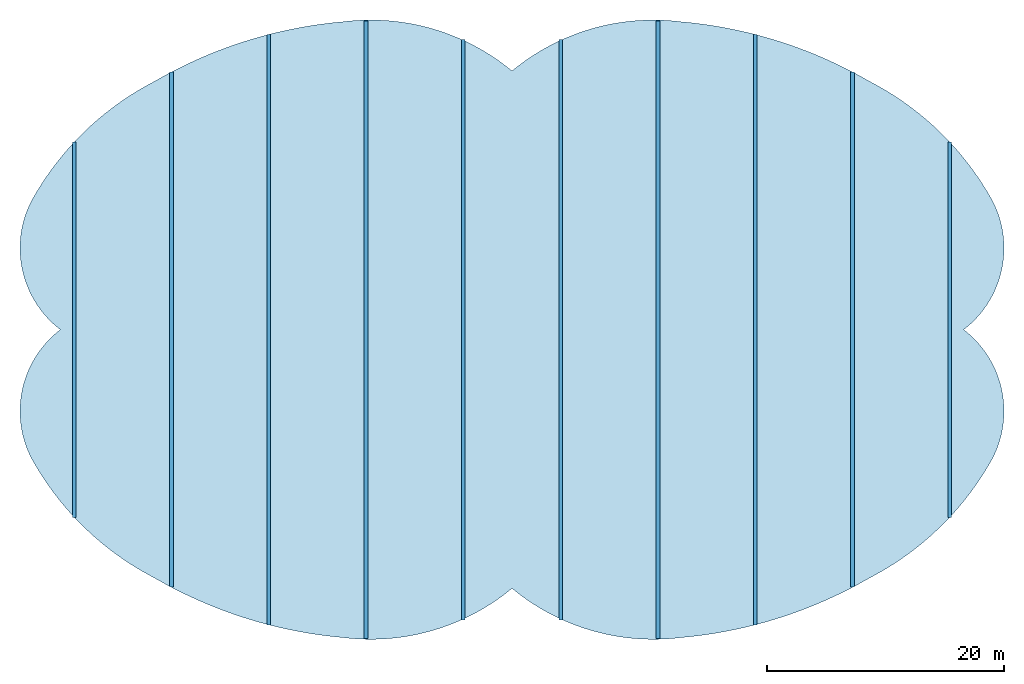
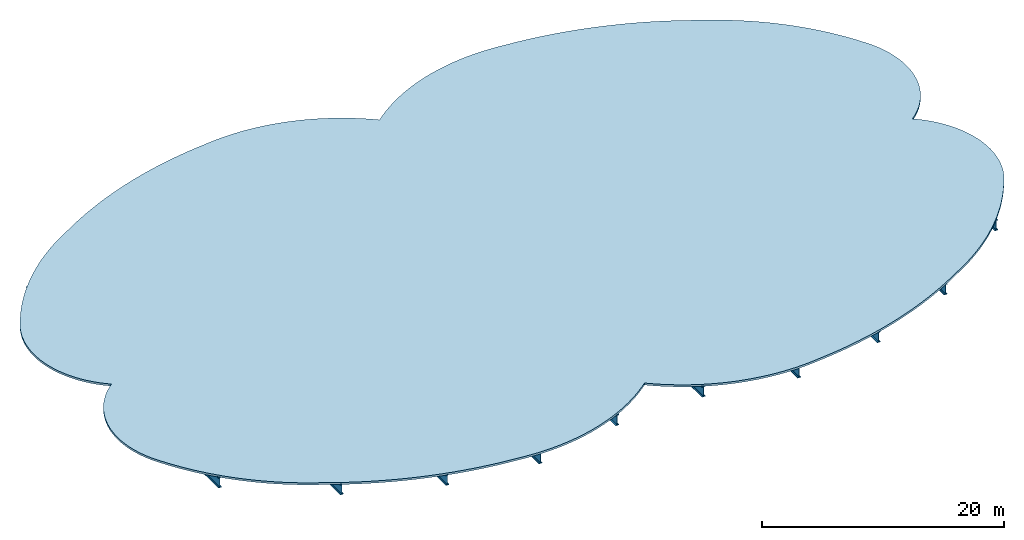
# One storey: 10 beams, 1 slab.
"""IFC2X3 building model written with IfcOpenShell, lengths in metres."""

from ifc_helpers import new_model, si_unit, point, direction, frame, frame_2d, origin_with_axes, origin_2d, place, context, project, spatial, circle_curve, parameter, trimmed, segment, composite_curve, i_section, outline, extrude, element, save


model = new_model("IFC2X3")

# Units and contexts
model_context = context("Model", 3, precision=1e-05, world=origin_with_axes(), true_north=direction((0.0, 1.0, 0.0)), identifier="Body")
ifc_project = project(units=[si_unit("LENGTHUNIT", "METRE"), si_unit("AREAUNIT", "SQUARE_METRE"), si_unit("VOLUMEUNIT", "CUBIC_METRE"), si_unit("PLANEANGLEUNIT", "RADIAN")], contexts=[model_context])

# Site, building, storey
site_placement = place(None, origin_with_axes())
site = spatial("IfcSite", under=ifc_project, at=site_placement, CompositionType="ELEMENT")
building_placement = place(None, origin_with_axes())
building = spatial("IfcBuilding", under=site, at=building_placement, Name="GH DEMO", CompositionType="ELEMENT")
storey_placement = place(None, origin_with_axes())
storey = spatial("IfcBuildingStorey", under=building, at=storey_placement, Name="FIRST FLOOR", CompositionType="ELEMENT", Elevation=3.0)

# Beams
beam_1_placement = place(None, origin_with_axes())
element("IfcBeam", 1, at=beam_1_placement, inside=storey, context=model_context, shape_type="SweptSolid", body=[
    extrude(i_section(OverallWidth=0.314, OverallDepth=1.056, WebThickness=0.036, FlangeThickness=0.064, FilletRadius=0.03, at=origin_2d()), frame((4.1125, -24.5321158359134, 2.5), z_axis=(0.0, 1.0, 0.0), x_axis=(-1.0, 0.0, 0.0)), (0.0, 0.0, 1.0), 49.0642316718267),
])
beam_2_placement = place(None, origin_with_axes())
element("IfcBeam", 2, at=beam_2_placement, inside=storey, context=model_context, shape_type="SweptSolid", body=[
    extrude(i_section(OverallWidth=0.314, OverallDepth=1.056, WebThickness=0.036, FlangeThickness=0.064, FilletRadius=0.03, at=origin_2d()), frame((12.3375, -26.1006955766967, 2.5), z_axis=(0.0, 1.0, 0.0), x_axis=(-1.0, 0.0, 0.0)), (0.0, 0.0, 1.0), 52.2013911533934),
])
beam_3_placement = place(None, origin_with_axes())
element("IfcBeam", 3, at=beam_3_placement, inside=storey, context=model_context, shape_type="SweptSolid", body=[
    extrude(i_section(OverallWidth=0.314, OverallDepth=1.056, WebThickness=0.036, FlangeThickness=0.064, FilletRadius=0.03, at=origin_2d()), frame((20.5625, -24.966524792191, 2.5), z_axis=(0.0, 1.0, 0.0), x_axis=(-1.0, 0.0, 0.0)), (0.0, 0.0, 1.0), 49.9330495843819),
])
beam_4_placement = place(None, origin_with_axes())
element("IfcBeam", 4, at=beam_4_placement, inside=storey, context=model_context, shape_type="SweptSolid", body=[
    extrude(i_section(OverallWidth=0.314, OverallDepth=1.056, WebThickness=0.036, FlangeThickness=0.064, FilletRadius=0.03, at=origin_2d()), frame((28.7875, -21.7760600789549, 2.5), z_axis=(0.0, 1.0, 0.0), x_axis=(-1.0, 0.0, 0.0)), (0.0, 0.0, 1.0), 43.5521201579098),
])
beam_5_placement = place(None, origin_with_axes())
element("IfcBeam", 5, at=beam_5_placement, inside=storey, context=model_context, shape_type="SweptSolid", body=[
    extrude(i_section(OverallWidth=0.314, OverallDepth=1.056, WebThickness=0.036, FlangeThickness=0.064, FilletRadius=0.03, at=origin_2d()), frame((37.0125, -15.8799742763678, 2.5), z_axis=(0.0, 1.0, 0.0), x_axis=(-1.0, 0.0, 0.0)), (0.0, 0.0, 1.0), 31.7599485527356),
])
beam_6_placement = place(None, origin_with_axes())
element("IfcBeam", 6, at=beam_6_placement, inside=storey, context=model_context, shape_type="SweptSolid", body=[
    extrude(i_section(OverallWidth=0.314, OverallDepth=1.056, WebThickness=0.036, FlangeThickness=0.064, FilletRadius=0.03, at=origin_2d()), frame((-4.1125, -24.5321158359134, 2.5), z_axis=(0.0, 1.0, 0.0), x_axis=(-1.0, 0.0, 0.0)), (0.0, 0.0, 1.0), 49.0642316718267),
])
beam_7_placement = place(None, origin_with_axes())
element("IfcBeam", 7, at=beam_7_placement, inside=storey, context=model_context, shape_type="SweptSolid", body=[
    extrude(i_section(OverallWidth=0.314, OverallDepth=1.056, WebThickness=0.036, FlangeThickness=0.064, FilletRadius=0.03, at=origin_2d()), frame((-12.3375, -26.1006955766967, 2.5), z_axis=(0.0, 1.0, 0.0), x_axis=(-1.0, 0.0, 0.0)), (0.0, 0.0, 1.0), 52.2013911533934),
])
beam_8_placement = place(None, origin_with_axes())
element("IfcBeam", 8, at=beam_8_placement, inside=storey, context=model_context, shape_type="SweptSolid", body=[
    extrude(i_section(OverallWidth=0.314, OverallDepth=1.056, WebThickness=0.036, FlangeThickness=0.064, FilletRadius=0.03, at=origin_2d()), frame((-20.5625, -24.966524792191, 2.5), z_axis=(0.0, 1.0, 0.0), x_axis=(-1.0, 0.0, 0.0)), (0.0, 0.0, 1.0), 49.9330495843819),
])
beam_9_placement = place(None, origin_with_axes())
element("IfcBeam", 9, at=beam_9_placement, inside=storey, context=model_context, shape_type="SweptSolid", body=[
    extrude(i_section(OverallWidth=0.314, OverallDepth=1.056, WebThickness=0.036, FlangeThickness=0.064, FilletRadius=0.03, at=origin_2d()), frame((-28.7875, -21.7760600789549, 2.5), z_axis=(0.0, 1.0, 0.0), x_axis=(-1.0, 0.0, 0.0)), (0.0, 0.0, 1.0), 43.5521201579098),
])
beam_10_placement = place(None, origin_with_axes())
element("IfcBeam", 10, at=beam_10_placement, inside=storey, context=model_context, shape_type="SweptSolid", body=[
    extrude(i_section(OverallWidth=0.314, OverallDepth=1.056, WebThickness=0.036, FlangeThickness=0.064, FilletRadius=0.03, at=origin_2d()), frame((-37.0125, -15.8799742763678, 2.5), z_axis=(0.0, 1.0, 0.0), x_axis=(-1.0, 0.0, 0.0)), (0.0, 0.0, 1.0), 31.7599485527356),
])

# Slab
slab_placement = place(None, origin_with_axes())
element("IfcSlab", 11, at=slab_placement, inside=storey, PredefinedType="NOTDEFINED", context=model_context, shape_type="SweptSolid", body=[
    extrude(outline(composite_curve([segment(trimmed(circle_curve(frame_2d((-10.9546335627703, 12.2199476322084), x_axis=(-0.50195152, -0.86489576)), 38.3960892071295), [parameter(0.439020028387402), point((-14.2845174768799, -38.2514253266515))], [parameter(0.0), point((-30.2276089739665, -20.988666991128))], False, "PARAMETER"), True, "CONTINUOUS"), segment(trimmed(circle_curve(frame_2d((-18.7682945251567, 1.2020695033539), x_axis=(-0.87430253, -0.48538139)), 24.9748808566555), [parameter(0.587314984636044), point((-30.227608973922, -22.1907364945027))], [parameter(0.0), point((-40.603895984039, -10.9202727922998))], False, "PARAMETER"), True, "CONTINUOUS"), segment(trimmed(circle_curve(frame_2d((-32.9099759605603, -6.8950303847377), x_axis=(-0.60783909, 0.79406023)), 8.68325870669296), [parameter(1.39947271324684), point((-40.6038959840913, -4.02524240746681))], [parameter(0.0), point((-38.1879999999831, 0.0))], False, "PARAMETER"), True, "CONTINUOUS"), segment(trimmed(circle_curve(frame_2d((-32.9099759604812, 6.89503038475521), x_axis=(-0.88606366, 0.46356357)), 8.68325870675497), [parameter(1.39947271323482), point((-38.1880000000095, -6.89503038474791))], [parameter(0.0), point((-40.6038959840758, 10.920272792234))], False, "PARAMETER"), True, "CONTINUOUS"), segment(trimmed(circle_curve(frame_2d((-18.7682945255943, -1.20206950290284), x_axis=(-0.4588336, 0.88852222)), 24.9748808560539), [parameter(0.587314984650611), point((-40.6038959840557, 12.1223422951725))], [parameter(0.0), point((-30.2276089739526, 20.9886669911331))], False, "PARAMETER"), True, "CONTINUOUS"), segment(trimmed(circle_curve(frame_2d((-10.9546335627704, -12.2199476322083), x_axis=(-0.08672456, 0.99623233)), 38.3960892071293), [parameter(0.439020028387404), point((-30.2276089739665, 33.2086146233363))], [parameter(0.0), point((-14.2845174768799, 26.0314776944431))], False, "PARAMETER"), True, "CONTINUOUS"), segment(trimmed(circle_curve(frame_2d((-11.9455871080853, 7.44569734517161), x_axis=(0.63769746, 0.77028693)), 18.7323737540519), [parameter(0.816692410029412), point((-14.2845174769113, 18.585780349269))], [parameter(0.0), point((0.0, 21.8749999999956))], False, "PARAMETER"), True, "CONTINUOUS"), segment(trimmed(circle_curve(frame_2d((11.9455871080856, 7.44569734517057), x_axis=(0.12486033, 0.99217433)), 18.7323737540528), [parameter(0.816692410029366), point((0.0, 14.4293026548252))], [parameter(0.0), point((14.2845174769115, 26.0314776944406))], False, "PARAMETER"), True, "CONTINUOUS"), segment(trimmed(circle_curve(frame_2d((10.9546335627781, -12.2199476321841), x_axis=(0.50195152, 0.86489576)), 38.3960892071046), [parameter(0.439020028387691), point((14.2845174768572, 38.2514253266292))], [parameter(0.0), point((30.2276089739468, 20.9886669911394))], False, "PARAMETER"), True, "CONTINUOUS"), segment(trimmed(circle_curve(frame_2d((18.7682945251567, -1.20206950335384), x_axis=(0.87430253, 0.48538139)), 24.9748808566554), [parameter(0.587314984636045), point((30.227608973992, 22.1907364944665))], [parameter(0.0), point((40.6038959840773, 10.9202727922308))], False, "PARAMETER"), True, "CONTINUOUS"), segment(trimmed(circle_curve(frame_2d((32.9099759605603, 6.89503038473771), x_axis=(0.60783909, -0.79406023)), 8.68325870669297), [parameter(1.39947271324684), point((40.6038959840944, 4.02524240746076))], [parameter(0.0), point((38.1879999999777, 0.0))], False, "PARAMETER"), True, "CONTINUOUS"), segment(trimmed(circle_curve(frame_2d((32.9099759604812, -6.89503038475521), x_axis=(0.88606366, -0.46356357)), 8.68325870675497), [parameter(1.39947271323482), point((38.1880000000095, 6.89503038474791))], [parameter(0.0), point((40.6038959840758, -10.920272792234))], False, "PARAMETER"), True, "CONTINUOUS"), segment(trimmed(circle_curve(frame_2d((18.7682945255943, 1.20206950290284), x_axis=(0.4588336, -0.88852222)), 24.9748808560539), [parameter(0.587314984650611), point((40.6038959840557, -12.1223422951725))], [parameter(0.0), point((30.2276089739526, -20.9886669911331))], False, "PARAMETER"), True, "CONTINUOUS"), segment(trimmed(circle_curve(frame_2d((10.9546335627704, 12.2199476322083), x_axis=(0.08672456, -0.99623233)), 38.3960892071293), [parameter(0.439020028387404), point((30.2276089739665, -33.2086146233363))], [parameter(0.0), point((14.2845174768799, -26.0314776944431))], False, "PARAMETER"), True, "CONTINUOUS"), segment(trimmed(circle_curve(frame_2d((11.9455871080853, -7.44569734517161), x_axis=(-0.63769746, -0.77028693)), 18.7323737540519), [parameter(0.816692410029412), point((14.2845174769113, -18.585780349269))], [parameter(0.0), point((0.0, -21.8749999999956))], False, "PARAMETER"), True, "CONTINUOUS"), segment(trimmed(circle_curve(frame_2d((-11.9455871080853, -7.44569734516482), x_axis=(-0.12486033, -0.99217433)), 18.7323737540571), [parameter(0.81669241002747), point((0.0, -14.4293026548307))], [parameter(0.0), point((-14.2845174768799, -26.0314776944431))], False, "PARAMETER"), True, "CONTINUOUS")], self_intersect="UNKNOWN")), frame((0.0, 0.0, 3.0), z_axis=(0.0, 0.0, 1.0), x_axis=(1.0, 0.0, 0.0)), (0.0, 0.0, 1.0), 0.203),
])

save(model, "model.ifc")
